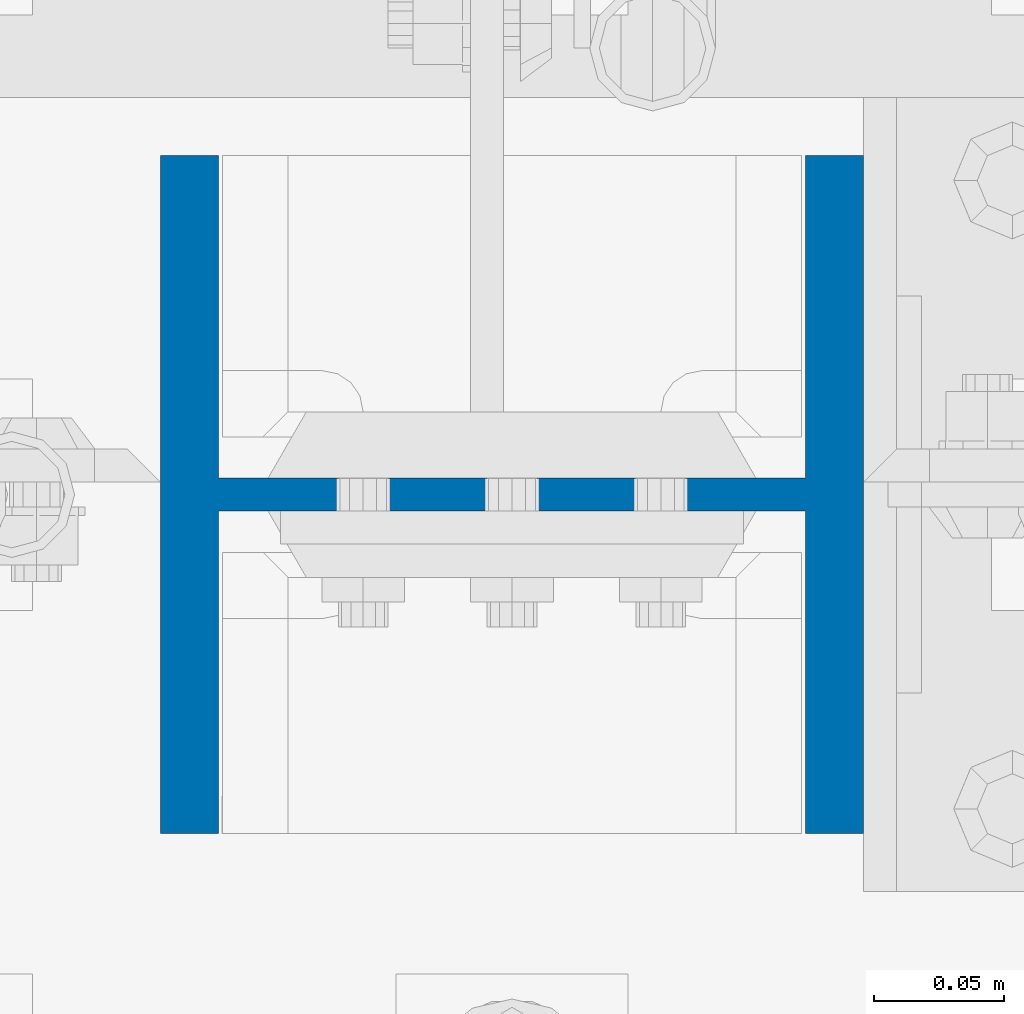
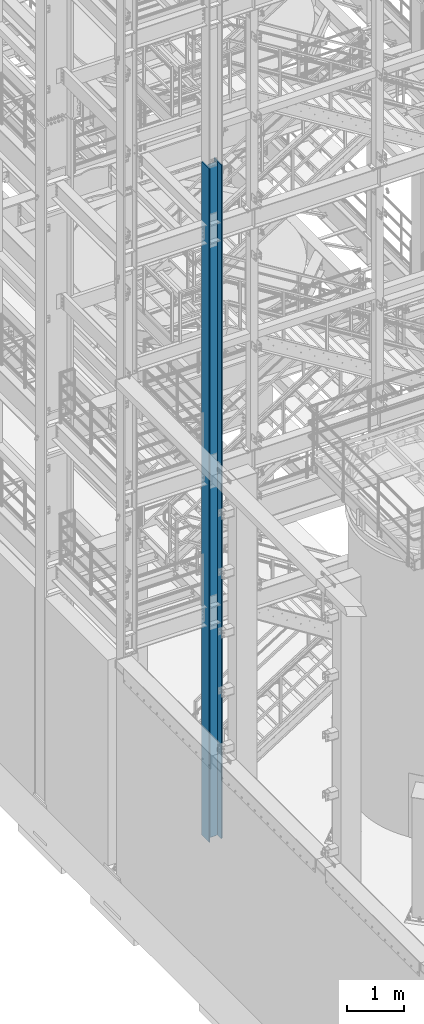
# One storey, part 570 of 1876: 1 column, 1 element without a shape of its own.
"""IFC2X3 building model written with IfcOpenShell, lengths in millimetres."""

from ifc_helpers import new_model, si_unit, frame, origin_with_axes, place, context, subcontext, project, spatial, faceted_brep, material, type_object, element, aggregate, save


model = new_model("IFC2X3")

# Units and contexts
model_context = context("Model", 3, precision=1e-05, world=origin_with_axes())
body_context = subcontext(model_context, "Body", "Model", "MODEL_VIEW")
ifc_project = project(units=[si_unit("LENGTHUNIT", "METRE", prefix="MILLI"), si_unit("AREAUNIT", "SQUARE_METRE"), si_unit("VOLUMEUNIT", "CUBIC_METRE"), si_unit("MASSUNIT", "GRAM", prefix="KILO"), si_unit("TIMEUNIT", "SECOND"), si_unit("PLANEANGLEUNIT", "RADIAN"), si_unit("SOLIDANGLEUNIT", "STERADIAN"), si_unit("THERMODYNAMICTEMPERATUREUNIT", "DEGREE_CELSIUS"), si_unit("LUMINOUSINTENSITYUNIT", "LUMEN")], contexts=[model_context])

# Site, building, storey
site_placement = place(None, origin_with_axes())
site = spatial("IfcSite", under=ifc_project, at=site_placement, CompositionType="ELEMENT")
building_placement = place(site_placement, origin_with_axes())
building = spatial("IfcBuilding", under=site, at=building_placement, Name="Undefined", CompositionType="ELEMENT")
storey_placement = place(building_placement, origin_with_axes())
storey = spatial("IfcBuildingStorey", under=building, at=storey_placement, Name="Undefined", CompositionType="ELEMENT", Elevation=0.0)

# Assembly, column
assembly_placement = place(storey_placement, origin_with_axes())
assembly = element("IfcElementAssembly", 1, at=assembly_placement, inside=storey, Name="COLUMN", AssemblyPlace="NOTDEFINED", PredefinedType="RIGID_FRAME")
ifc_material = material(Name="STEEL/A992")
column_type = type_object("IfcColumnType", Name="W10X77", PredefinedType="NOTDEFINED")
column_placement = place(assembly_placement, frame((1727.2, -7112.0, 0.0), z_axis=(-1.0, 0.0, 0.0), x_axis=(0.0, 0.0, 1.0)))
column = element("IfcColumn", 2, at=column_placement, type_object=column_type, material=ifc_material, Name="COLUMN", ObjectType="W10X77", context=body_context, shape_type="Brep", body=[
    faceted_brep([(107.95, -6.35000000000036, 88.5755937151584), (101.600000762938, -7.6293963502394e-07, 87.3125003340556), (95.25, 6.35000000000036, 87.3125003340556), (95.25, 6.35000000000036, -87.3125003814696), (101.600000762939, -7.62940544518642e-07, -87.3125003814696), (107.95, -6.35000000000036, -88.5755937625725), (14528.8, -130.175, 134.9375), (14528.8, 130.175, 134.9375), (117.475, 130.175, 134.9375), (117.475, -130.175, 134.9375), (120.649999999998, -130.175, 112.7125), (14497.05, -130.175, 112.7125), (14528.8, -130.175, 112.7125), (95.25, -130.175, 112.7125), (120.649999999999, -6.35000000000036, 112.712499952586), (14497.05, -6.35000000000036, 112.7125), (14528.8, -6.35000000000036, 112.7125), (95.25, -6.35000000000036, 112.7125), (14528.8, -130.175, -134.9375), (14528.8, -130.175, -112.7125), (14497.05, -130.175, -112.7125), (120.649999999998, -130.175, -112.7125), (95.25, -130.175, -112.7125), (117.475, -130.175, -134.9375), (14528.8, 130.175, -134.9375), (117.475, 130.175, -134.9375), (120.649999999998, 130.175, -112.7125), (14497.05, 130.175, -112.7125), (14528.8, 130.175, -112.7125), (95.25, 130.175, -112.7125), (14528.8, 6.35000000000036, -112.7125), (14528.8, -6.35000000000036, -112.7125), (14497.05, -6.35000000000036, -112.7125), (120.649999999998, -6.35000000000036, -112.7125), (95.25, -6.35000000000036, -112.7125), (108.89011985753, -6.35000000000036, -88.7625952290543), (108.89011985753, 6.35000000000036, -88.7625952290543), (115.070384405063, 6.35000000000036, -92.8921159764066), (115.070384405063, -6.35000000000036, -92.8921159764066), (119.199905152415, 6.35000000000036, -99.0723805239406), (119.199905152415, -6.35000000000036, -99.0723805239406), (120.649999999999, 6.35000000000036, -106.362499618532), (120.649999999999, -6.35000000000036, -106.362499618532), (120.649999999998, 6.35000000000036, -112.7125), (95.25, 6.35000000000036, -112.7125), (14497.05, 6.35000000000036, -112.7125), (14498.6039556076, 6.35000000000036, -102.901210428596), (14498.6039556076, -6.35000000000036, -102.901210428596), (14503.1137104286, 6.35000000000036, -94.050318239714), (14503.1137104286, -6.35000000000036, -94.050318239714), (14510.1378182397, 6.35000000000036, -87.0262104285955), (14510.1378182397, -6.35000000000036, -87.0262104285955), (14518.9887104286, 6.35000000000036, -82.516455607629), (14518.9887104286, -6.35000000000036, -82.516455607629), (14528.8, -6.35000000000036, -80.9625000000001), (14528.8, 6.35000000000036, -80.9625000000001), (14528.8, 6.35000000000036, 80.9625000000001), (14528.8, -6.35000000000036, 80.9625000000001), (14518.9887104286, 6.35000000000036, 82.516455607629), (14518.9887104286, -6.35000000000036, 82.516455607629), (14510.1378182397, 6.35000000000036, 87.0262104285955), (14510.1378182397, -6.35000000000036, 87.0262104285955), (14503.1137104286, 6.35000000000036, 94.050318239714), (14503.1137104286, -6.35000000000036, 94.050318239714), (14498.6039556076, 6.35000000000036, 102.901210428596), (14498.6039556076, -6.35000000000036, 102.901210428596), (14497.05, 6.35000000000036, 112.7125), (14528.8, 6.35000000000036, 112.7125), (14528.8, 130.175, 112.7125), (14497.05, 130.175, 112.7125), (120.649999999998, 130.175, 112.7125), (95.25, 130.175, 112.7125), (95.25, 6.35000000000036, 112.7125), (120.649999999998, 6.35000000000036, 112.7125), (120.649999999999, 6.35000000000036, 106.362499571116), (120.649999999999, -6.35000000000036, 106.362499571116), (119.199905152414, 6.35000000000036, 99.0723804765255), (119.199905152414, -6.35000000000036, 99.0723804765255), (115.070384405062, 6.35000000000036, 92.8921159289921), (115.070384405062, -6.35000000000036, 92.8921159289921), (108.890119857529, 6.35000000000036, 88.7625951816403), (108.890119857529, -6.35000000000036, 88.7625951816403), (101.600000762939, 6.35000000000036, -87.3125003814696), (101.600000762938, 6.35000000000036, 87.3125003340556)], [[[0, 1, 2, 3, 4, 5]], [[6, 7, 8, 9]], [[10, 11, 12, 6, 9, 13]], [[14, 15, 16, 12, 11, 10, 13, 17]], [[18, 19, 20, 21, 22, 23]], [[24, 18, 23, 25]], [[26, 27, 28, 24, 25, 29]], [[19, 18, 24, 28, 30, 31]], [[21, 20, 19, 31, 32, 33, 34, 22]], [[35, 36, 37, 38]], [[38, 37, 39, 40]], [[40, 39, 41, 42]], [[42, 41, 43, 33]], [[33, 43, 44, 34]], [[29, 25, 23, 22, 34, 44]], [[43, 45, 30, 28, 27, 26, 29, 44]], [[31, 30, 45, 32]], [[32, 45, 46, 47]], [[47, 46, 48, 49]], [[49, 48, 50, 51]], [[51, 50, 52, 53]], [[54, 53, 52, 55]], [[56, 57, 54, 55]], [[57, 56, 58, 59]], [[59, 58, 60, 61]], [[61, 60, 62, 63]], [[63, 62, 64, 65]], [[65, 64, 66, 15]], [[16, 15, 66, 67]], [[68, 7, 6, 12, 16, 67]], [[7, 68, 69, 70, 71, 8]], [[13, 9, 8, 71, 72, 17]], [[70, 69, 68, 67, 66, 73, 72, 71]], [[17, 72, 73, 14]], [[14, 73, 74, 75]], [[75, 74, 76, 77]], [[77, 76, 78, 79]], [[79, 78, 80, 81]], [[35, 38, 40, 42, 33, 32, 47, 49, 51, 53, 54, 57, 59, 61, 63, 65, 15, 14, 75, 77, 79, 81, 0, 5]], [[82, 36, 35, 5, 4]], [[82, 4, 3]], [[83, 80, 78, 76, 74, 73, 66, 64, 62, 60, 58, 56, 55, 52, 50, 48, 46, 45, 43, 41, 39, 37, 36, 82, 3, 2]], [[83, 2, 1]], [[81, 80, 83, 1, 0]]]),
])
aggregate(assembly, [column])

save(model, "model.ifc")
